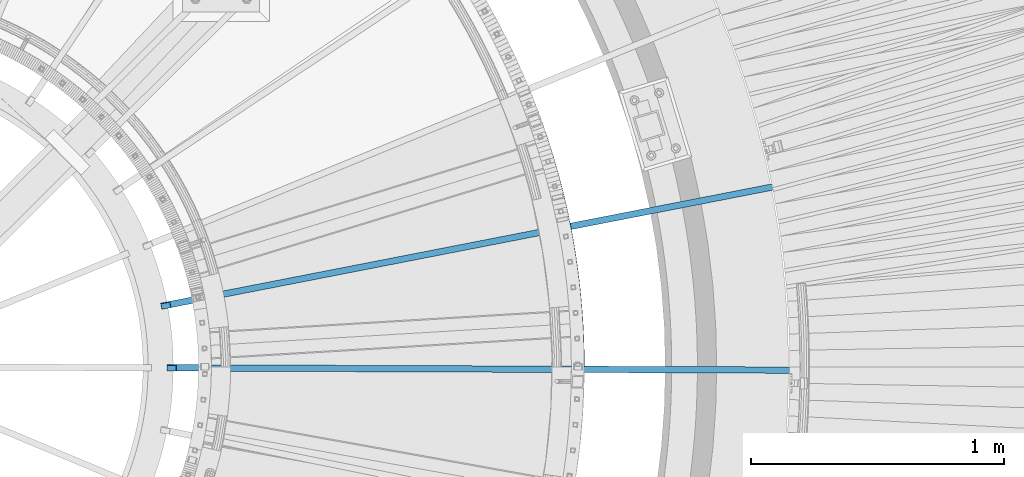
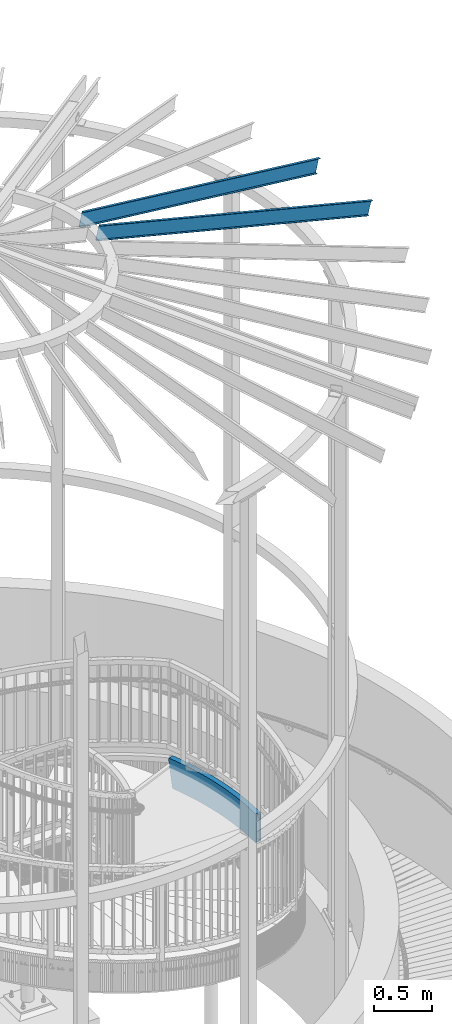
# One storey, part 364 of 975: 3 beams.
"""IFC2X3 building model written with IfcOpenShell, lengths in millimetres."""

from ifc_helpers import new_model, si_unit, frame, origin_with_axes, place, context, subcontext, project, spatial, faceted_brep, material, type_object, element, save


model = new_model("IFC2X3")

# Units and contexts
model_context = context("Model", 3, precision=1e-05, world=origin_with_axes())
body_context = subcontext(model_context, "Body", "Model", "MODEL_VIEW")
ifc_project = project(units=[si_unit("LENGTHUNIT", "METRE", prefix="MILLI"), si_unit("AREAUNIT", "SQUARE_METRE"), si_unit("VOLUMEUNIT", "CUBIC_METRE"), si_unit("MASSUNIT", "GRAM", prefix="KILO"), si_unit("TIMEUNIT", "SECOND"), si_unit("PLANEANGLEUNIT", "RADIAN"), si_unit("SOLIDANGLEUNIT", "STERADIAN"), si_unit("THERMODYNAMICTEMPERATUREUNIT", "DEGREE_CELSIUS"), si_unit("LUMINOUSINTENSITYUNIT", "LUMEN")], contexts=[model_context])

# Site, building, storey
site_placement = place(None, origin_with_axes())
site = spatial("IfcSite", under=ifc_project, at=site_placement, CompositionType="ELEMENT")
building_placement = place(site_placement, origin_with_axes())
building = spatial("IfcBuilding", under=site, at=building_placement, Name="Undefined", CompositionType="ELEMENT")
storey_placement = place(building_placement, origin_with_axes())
storey = spatial("IfcBuildingStorey", under=building, at=storey_placement, Name="Undefined", CompositionType="ELEMENT", Elevation=0.0)

# Beams
ifc_material_1 = material()
beam_type_1 = type_object("IfcBeamType", Name="HSS12X2X5/16", PredefinedType="NOTDEFINED")
beam_placement = place(storey_placement, frame((37376.4468906606, 4525.99145392499, 2031.99999923706), z_axis=(0.0, 0.0, 1.0), x_axis=(0.0625371900182985, -0.99804263429205, 0.0)))
element("IfcBeam", 1, at=beam_placement, inside=storey, type_object=beam_type_1, material=ifc_material_1, Name="STAIR", ObjectType="HSS12X2X5/16", context=body_context, shape_type="Brep", body=[
    faceted_brep([(50.4767882712349, -9.42974077601684, -152.4), (42.9468978576706, -11.9601611467078, -144.457192089878), (40.2846474015082, -4.48124712339632, -144.434568420989), (40.3111269200131, -4.47234867874795, -144.4625), (28.6915941205434, 28.4665858047883, -144.4625), (28.5707453943933, 28.4259745791787, -144.335024277875), (25.90849493823, 35.9048886024902, -144.312400608985), (33.5756496538238, 38.4814366545834, -152.4), (5.84921235797265, -16.4537418553809, 144.4625), (36.8046028404979, -5.65071642034309, 144.4625), (36.8046028404979, -5.65071642034309, -119.316739082641), (5.84921235797265, -16.4537418553809, 105.027080408093), (0.43018889700852, -18.4155836698192, 144.4625), (67.8829967902311, 4.79318074406183, -144.4625), (67.8829967902311, 4.79318074406183, 144.4625), (99.0802279445834, 14.8765495649059, 144.4625), (99.0802279445834, 14.8765495649059, -144.4625), (130.392114110062, 24.5980383004644, 144.4625), (130.392114110062, 24.5980383004644, -144.4625), (161.814457722915, 33.9563437213947, 144.4625), (161.814457722915, 33.9563437213947, -144.4625), (193.343046411844, 42.9502112854461, 144.4625), (193.343046411844, 42.9502112854461, -144.4625), (224.973653562703, 51.5784353056879, 144.4625), (224.973653562703, 51.5784353056879, -144.4625), (256.702038885101, 59.8398591120786, 144.4625), (256.702038885101, 59.8398591120786, -144.4625), (288.523948980843, 67.7333752065606, 144.4625), (288.523948980843, 67.7333752065606, -144.4625), (320.435117914123, 75.2579254115335, 144.4625), (320.435117914123, 75.2579254115335, -144.4625), (352.431267783404, 82.4125010116622, 144.4625), (352.431267783404, 82.4125010116622, -144.4625), (384.508109294894, 89.1961428891591, 144.4625), (384.508109294894, 89.1961428891591, -144.4625), (416.66134233756, 95.607941652328, 144.4625), (416.66134233756, 95.607941652328, -144.4625), (448.886656559584, 101.647037757473, 144.4625), (448.886656559584, 101.647037757473, -144.4625), (481.179731946188, 107.312621624165, 144.4625), (481.179731946188, 107.312621624165, -144.4625), (513.536239398771, 112.603933743696, 144.4625), (513.536239398771, 112.603933743696, -144.4625), (545.951841315243, 117.520264780986, 144.4625), (545.951841315243, 117.520264780986, -144.4625), (578.422192171517, 122.060955669585, 144.4625), (578.422192171517, 122.060955669585, -144.4625), (610.942939104049, 126.225397700116, 144.4625), (610.942939104049, 126.225397700116, -144.4625), (643.509722493372, 130.013032601797, 144.4625), (643.509722493372, 130.013032601797, -144.4625), (676.118176548528, 133.423352617305, 144.4625), (676.118176548528, 133.423352617305, -144.4625), (708.763929892335, 136.455900570894, 144.4625), (708.763929892335, 136.455900570894, -144.4625), (741.442606147396, 139.110269929603, 144.4625), (741.442606147396, 139.110269929603, -144.4625), (774.149824522779, 141.386104857796, 144.4625), (774.149824522779, 141.386104857796, -144.4625), (806.8812004013, 143.283100264904, 144.4625), (806.8812004013, 143.283100264904, -144.4625), (839.632345927297, 144.801001846223, 144.4625), (839.632345927297, 144.801001846223, -144.4625), (872.39887059486, 145.939606117092, 144.4625), (872.39887059486, 145.939606117092, -144.4625), (905.176381836402, 146.698760440137, 144.4625), (905.176381836402, 146.698760440137, -144.4625), (937.960485611517, 147.078363045752, 144.4625), (937.960485611517, 147.078363045752, -144.4625), (970.746786996023, 147.078363045708, 144.4625), (970.746786996023, 147.078363045708, -144.4625), (1003.53089077114, 146.698760440006, 144.4625), (1003.53089077114, 146.698760440006, -144.4625), (1036.30840201268, 145.939606116859, 144.4625), (1036.30840201268, 145.939606116859, -144.4625), (1069.07492668024, 144.801001845903, 144.4625), (1069.07492668024, 144.801001845903, -144.4625), (1101.82607220624, 143.283100264496, 144.4625), (1101.82607220624, 143.283100264496, -144.4625), (1133.45592378993, 141.449945330613, 144.4625), (1133.45592378993, 141.449945330613, -144.4625), (56.9496687240271, 37.962714391746, 144.4625), (56.9496687240271, 37.962714391746, -144.4625), (88.5316724221789, 48.1704469246324, -144.4625), (88.5316724221789, 48.1704469246324, 144.4625), (120.229745234523, 58.0118361068453, -144.4625), (120.229745234523, 58.0118361068453, 144.4625), (152.039637826455, 67.4855626356511, -144.4625), (152.039637826455, 67.4855626356511, 144.4625), (183.957085873196, 76.590356495828, -144.4625), (183.957085873196, 76.590356495828, 144.4625), (215.977810631451, 85.3249971300465, -144.4625), (215.977810631451, 85.3249971300465, 144.4625), (248.097519513003, 93.6883136024044, -144.4625), (248.097519513003, 93.6883136024044, 144.4625), (280.311906660169, 101.679184755492, -144.4625), (280.311906660169, 101.679184755492, 144.4625), (312.616653523017, 109.296539360599, -144.4625), (312.616653523017, 109.296539360599, 144.4625), (345.007429438308, 116.539356261368, -144.4625), (345.007429438308, 116.539356261368, 144.4625), (377.479892210042, 123.40666451068, -144.4625), (377.479892210042, 123.40666451068, 144.4625), (410.029688691558, 129.897543500811, -144.4625), (410.029688691558, 129.897543500811, 144.4625), (442.652455369106, 136.011123086857, -144.4625), (442.652455369106, 136.011123086857, 144.4625), (475.343818946802, 141.74658370336, -144.4625), (475.343818946802, 141.74658370336, 144.4625), (508.0993969329, 147.103156474215, -144.4625), (508.0993969329, 147.103156474215, 144.4625), (540.914798227285, 152.080123315682, -144.4625), (540.914798227285, 152.080123315682, 144.4625), (573.785623710142, 156.67681703272, -144.4625), (573.785623710142, 156.67681703272, 144.4625), (606.707466831677, 160.892621408377, -144.4625), (606.707466831677, 160.892621408377, 144.4625), (639.675914202845, 164.726971286414, -144.4625), (639.675914202845, 164.726971286414, 144.4625), (672.686546186998, 168.179352647094, -144.4625), (672.686546186998, 168.179352647094, 144.4625), (705.734937492365, 171.24930267602, -144.4625), (705.734937492365, 171.24930267602, 144.4625), (738.816657765287, 173.936409826274, -144.4625), (738.816657765287, 173.936409826274, 144.4625), (771.927272184139, 176.24031387351, -144.4625), (771.927272184139, 176.24031387351, 144.4625), (805.06234205385, 178.160705964263, -144.4625), (805.06234205385, 178.160705964263, 144.4625), (838.21742540093, 179.697328657392, -144.4625), (838.21742540093, 179.697328657392, 144.4625), (871.388077568954, 180.849975958547, -144.4625), (871.388077568954, 180.849975958547, 144.4625), (904.569851814394, 181.618493347778, -144.4625), (904.569851814394, 181.618493347778, 144.4625), (937.758299902736, 182.002777800299, -144.4625), (937.758299902736, 182.002777800299, 144.4625), (970.94897270479, 182.002777800255, -144.4625), (970.94897270479, 182.002777800255, 144.4625), (1004.13742079313, 181.618493347632, -144.4625), (1004.13742079313, 181.618493347632, 144.4625), (1037.31919503857, 180.849975958314, -144.4625), (1037.31919503857, 180.849975958314, 144.4625), (1070.4898472066, 179.697328657072, -144.4625), (1070.4898472066, 179.697328657072, 144.4625), (1103.64493055368, 178.160705963848, -144.4625), (1103.64493055368, 178.160705963848, 144.4625), (1135.64002253457, 176.306382981355, -144.4625), (1135.64002253457, 176.306382981355, 144.4625), (1136.1364086129, 184.228300629249, 144.4625), (1136.13640861289, 184.228300629249, -144.4625), (1104.05830745082, 186.087434531888, -152.4), (1104.05830745082, 186.087434531888, 152.4), (1128.21211871852, 184.687564596352, 152.4), (1128.21211916117, 184.687564570697, -152.4), (1070.8114200535, 187.628312023255, -152.4), (1070.8114200535, 187.628312023255, 152.4), (1037.54892072627, 188.784150922278, -152.4), (1037.54892072627, 188.784150922278, 152.4), (1004.2752685254, 189.554796281198, -152.4), (1004.2752685254, 189.554796281198, 152.4), (970.994924002237, 189.940144789914, -152.4), (970.994924002237, 189.940144789914, 152.4), (937.712348605286, 189.940144789965, -152.4), (937.712348605286, 189.940144789965, 152.4), (904.43200408212, 189.554796281329, -152.4), (904.43200408212, 189.554796281329, 152.4), (871.158351881248, 188.784150922511, -152.4), (871.158351881248, 188.784150922511, 152.4), (837.895852554028, 187.628312023582, -152.4), (837.895852554028, 187.628312023582, 152.4), (804.648965156702, 186.087434532303, -152.4), (804.648965156702, 186.087434532303, 152.4), (771.42214665263, 184.161725013444, -152.4), (771.42214665263, 184.161725013444, 152.4), (738.219851314807, 181.851441620973, -152.4), (738.219851314807, 181.851441620973, 152.4), (705.046530128735, 179.156894063555, -152.4), (705.046530128735, 179.156894063555, 152.4), (671.906630195741, 176.078443562947, -152.4), (671.906630195741, 176.078443562947, 152.4), (638.804594136816, 172.616502805649, -152.4), (638.804594136816, 172.616502805649, 152.4), (605.744859497046, 168.771535887528, -152.4), (605.744859497046, 168.771535887528, 152.4), (572.731858150739, 164.544058251617, -152.4), (572.731858150739, 164.544058251617, 152.4), (539.770015707295, 159.934636619022, -152.4), (539.770015707295, 159.934636619022, 152.4), (506.863750917929, 154.943888912967, -152.4), (506.863750917929, 154.943888912967, 152.4), (474.017475083306, 149.572484175907, -152.4), (474.017475083306, 149.572484175907, 152.4), (441.235591462179, 143.821142479901, -152.4), (441.235591462179, 143.821142479901, 152.4), (408.522494681103, 137.690634830011, -152.4), (408.522494681103, 137.690634830011, 152.4), (375.882570145302, 131.181783061016, -152.4), (375.882570145302, 131.181783061016, 152.4), (343.320193450787, 124.295459727211, -152.4), (343.320193450787, 124.295459727211, 152.4), (310.839729797766, 117.032587985392, -152.4), (310.839729797766, 117.032587985392, 152.4), (278.44553340547, 109.394141471159, -152.4), (278.44553340547, 109.394141471159, 152.4), (246.141946928435, 101.381144168394, -152.4), (246.141946928435, 101.381144168394, 152.4), (213.933300874347, 92.994670271939, -152.4), (213.933300874347, 92.994670271939, 152.4), (181.823913023502, 84.2358440436437, -152.4), (181.823913023502, 84.2358440436437, 152.4), (149.818087849988, 75.1058396616208, -152.4), (149.818087849988, 75.1058396616208, 152.4), (117.920115944627, 65.6058810628529, -152.4), (117.920115944627, 65.6058810628529, 152.4), (86.1342734398131, 55.7372417791048, -152.4), (86.1342734398131, 55.7372417791048, 152.4), (54.4648214362537, 45.501244766223, -152.4), (54.4648214362537, 45.501244766223, 152.4), (22.9160054317458, 34.8992622267615, -122.713585018293), (22.9160054317458, 34.8992622267615, 152.4), (-8.50794524795992, 23.93271542601, 105.026043171934), (-8.50794524795992, 23.93271542601, 150.251089587742), (-6.47902665908623, 24.6407814132108, 152.4), (-13.930158757054, 21.9697187227212, 144.484677442171), (8.50794524795947, -23.9327154259954, 105.027272488863), (39.3765653235992, -13.1599717253703, -118.687693539002), (39.3765653235992, -13.1599717253703, 152.4), (10.4203217331333, -23.2653211050638, 152.4), (8.50794524795947, -23.9327154259954, 150.374524082099), (3.07108006647468, -25.9010164546562, 144.592530185369), (70.3678440780036, -2.74534963041515, 152.4), (101.477626926949, 7.30975471043348, 152.4), (132.701743399958, 17.0039933444714, 152.4), (164.036007699384, 26.336066695425, 152.4), (195.476219261537, 35.3047237376304, 152.4), (227.018163319806, 43.9087621637882, 152.4), (258.65761146967, 52.1470285460964, 152.4), (290.390322235542, 60.0184184909012, 152.4), (322.212041639375, 67.5218767867409, 152.4), (354.118503770926, 74.6563975458121, 152.4), (386.105431359633, 81.4210243388079, 152.4), (418.168536348015, 87.8148503231132, 152.4), (450.303520466511, 93.8370183644365, 152.4), (482.506075809685, 99.4867211516103, 152.4), (514.771885413742, 104.763201304937, 152.4), (547.096623835234, 109.665751477638, 152.4), (579.47595773092, 114.193714450696, 152.4), (611.905546438679, 118.346483220965, 152.4), (644.381042559401, 122.123501082555, 152.4), (676.898092539784, 125.524261701445, 152.4), (709.452337255965, 128.548309183367, 152.4), (742.039412597875, 131.195238134904, 152.4), (774.654950054289, 133.464693717877, 152.4), (807.294577298449, 135.356371696871, 152.4), (839.953918774198, 136.870018480047, 152.4), (872.628596282565, 138.005431153128, 152.4), (905.314229568676, 138.762457506586, 152.4), (938.006436908966, 139.140996056085, 152.4), (970.700835698576, 139.140996056034, 152.4), (1003.39304303887, 138.762457506447, 152.4), (1036.07867632498, 138.005431152895, 152.4), (1068.75335383335, 136.870018479727, 152.4), (1101.4126953091, 135.356371696456, 152.4), (1125.03524781722, 133.987291649828, 152.4), (1132.9595377116, 133.528027682718, 144.4625), (1101.4126953091, 135.356371696456, -152.4), (1125.03524825988, 133.987291624166, -152.4), (1132.9595377116, 133.528027682718, -144.4625), (1068.75335383335, 136.870018479727, -152.4), (1036.07867632498, 138.005431152895, -152.4), (1003.39304303887, 138.762457506447, -152.4), (970.700835698576, 139.140996056034, -152.4), (938.006436908966, 139.140996056085, -152.4), (905.314229568676, 138.762457506586, -152.4), (872.628596282565, 138.005431153128, -152.4), (839.953918774198, 136.870018480047, -152.4), (807.294577298449, 135.356371696871, -152.4), (774.654950054289, 133.464693717877, -152.4), (742.039412597875, 131.195238134904, -152.4), (709.452337255965, 128.548309183367, -152.4), (676.898092539784, 125.524261701445, -152.4), (644.381042559401, 122.123501082555, -152.4), (611.905546438679, 118.346483220965, -152.4), (579.47595773092, 114.193714450696, -152.4), (547.096623835234, 109.665751477638, -152.4), (514.771885413742, 104.763201304937, -152.4), (482.506075809685, 99.4867211516103, -152.4), (450.303520466511, 93.8370183644365, -152.4), (418.168536348015, 87.8148503231132, -152.4), (386.105431359633, 81.4210243388079, -152.4), (354.118503770926, 74.6563975458121, -152.4), (322.212041639375, 67.5218767867409, -152.4), (290.390322235542, 60.0184184909012, -152.4), (258.65761146967, 52.1470285460964, -152.4), (227.018163319806, 43.9087621637882, -152.4), (195.476219261537, 35.3047237376304, -152.4), (164.036007699384, 26.336066695425, -152.4), (132.701743399958, 17.0039933444714, -152.4), (101.477626926949, 7.30975471043348, -152.4), (70.3678440780036, -2.74534963041515, -152.4), (-11.2683519560769, 14.4918579959703, 144.4625), (-5.84921235797174, 16.4537418553809, 144.4625), (25.4879679148476, 27.3900069217416, 144.4625), (-5.84921235797174, 16.4537418553809, 105.026235252704), (25.4879679148476, 27.3900069217416, -122.084539474654)], [[[0, 1, 2, 3, 4, 5, 6, 7]], [[8, 9, 10, 11]], [[8, 11, 12]], [[13, 14, 15, 16]], [[16, 15, 17, 18]], [[18, 17, 19, 20]], [[20, 19, 21, 22]], [[22, 21, 23, 24]], [[24, 23, 25, 26]], [[26, 25, 27, 28]], [[28, 27, 29, 30]], [[30, 29, 31, 32]], [[32, 31, 33, 34]], [[34, 33, 35, 36]], [[36, 35, 37, 38]], [[38, 37, 39, 40]], [[40, 39, 41, 42]], [[42, 41, 43, 44]], [[44, 43, 45, 46]], [[46, 45, 47, 48]], [[48, 47, 49, 50]], [[50, 49, 51, 52]], [[52, 51, 53, 54]], [[54, 53, 55, 56]], [[56, 55, 57, 58]], [[58, 57, 59, 60]], [[60, 59, 61, 62]], [[62, 61, 63, 64]], [[64, 63, 65, 66]], [[66, 65, 67, 68]], [[68, 67, 69, 70]], [[70, 69, 71, 72]], [[72, 71, 73, 74]], [[74, 73, 75, 76]], [[76, 75, 77, 78]], [[78, 77, 79, 80]], [[81, 82, 83, 84]], [[84, 83, 85, 86]], [[86, 85, 87, 88]], [[88, 87, 89, 90]], [[90, 89, 91, 92]], [[92, 91, 93, 94]], [[94, 93, 95, 96]], [[96, 95, 97, 98]], [[98, 97, 99, 100]], [[100, 99, 101, 102]], [[102, 101, 103, 104]], [[104, 103, 105, 106]], [[106, 105, 107, 108]], [[108, 107, 109, 110]], [[110, 109, 111, 112]], [[112, 111, 113, 114]], [[114, 113, 115, 116]], [[116, 115, 117, 118]], [[118, 117, 119, 120]], [[120, 119, 121, 122]], [[122, 121, 123, 124]], [[124, 123, 125, 126]], [[126, 125, 127, 128]], [[128, 127, 129, 130]], [[130, 129, 131, 132]], [[132, 131, 133, 134]], [[134, 133, 135, 136]], [[136, 135, 137, 138]], [[138, 137, 139, 140]], [[140, 139, 141, 142]], [[142, 141, 143, 144]], [[144, 143, 145, 146]], [[146, 145, 147, 148]], [[149, 148, 147, 150]], [[151, 152, 153, 149, 150, 154]], [[155, 156, 152, 151]], [[157, 158, 156, 155]], [[159, 160, 158, 157]], [[161, 162, 160, 159]], [[163, 164, 162, 161]], [[165, 166, 164, 163]], [[167, 168, 166, 165]], [[169, 170, 168, 167]], [[171, 172, 170, 169]], [[173, 174, 172, 171]], [[175, 176, 174, 173]], [[177, 178, 176, 175]], [[179, 180, 178, 177]], [[181, 182, 180, 179]], [[183, 184, 182, 181]], [[185, 186, 184, 183]], [[187, 188, 186, 185]], [[189, 190, 188, 187]], [[191, 192, 190, 189]], [[193, 194, 192, 191]], [[195, 196, 194, 193]], [[197, 198, 196, 195]], [[199, 200, 198, 197]], [[201, 202, 200, 199]], [[203, 204, 202, 201]], [[205, 206, 204, 203]], [[207, 208, 206, 205]], [[209, 210, 208, 207]], [[211, 212, 210, 209]], [[213, 214, 212, 211]], [[215, 216, 214, 213]], [[217, 218, 216, 215]], [[219, 220, 218, 217, 7, 6]], [[220, 219, 221, 222, 223]], [[221, 224, 222]], [[225, 226, 227, 228, 229]], [[225, 229, 230]], [[228, 223, 222, 224, 230, 229]], [[227, 231, 232, 233, 234, 235, 236, 237, 238, 239, 240, 241, 242, 243, 244, 245, 246, 247, 248, 249, 250, 251, 252, 253, 254, 255, 256, 257, 258, 259, 260, 261, 262, 263, 264, 153, 152, 156, 158, 160, 162, 164, 166, 168, 170, 172, 174, 176, 178, 180, 182, 184, 186, 188, 190, 192, 194, 196, 198, 200, 202, 204, 206, 208, 210, 212, 214, 216, 218, 220, 223, 228]], [[265, 264, 263, 266, 267, 268]], [[262, 269, 266, 263]], [[261, 270, 269, 262]], [[260, 271, 270, 261]], [[259, 272, 271, 260]], [[258, 273, 272, 259]], [[257, 274, 273, 258]], [[256, 275, 274, 257]], [[255, 276, 275, 256]], [[254, 277, 276, 255]], [[253, 278, 277, 254]], [[252, 279, 278, 253]], [[251, 280, 279, 252]], [[250, 281, 280, 251]], [[249, 282, 281, 250]], [[248, 283, 282, 249]], [[247, 284, 283, 248]], [[246, 285, 284, 247]], [[245, 286, 285, 246]], [[244, 287, 286, 245]], [[243, 288, 287, 244]], [[242, 289, 288, 243]], [[241, 290, 289, 242]], [[240, 291, 290, 241]], [[239, 292, 291, 240]], [[238, 293, 292, 239]], [[237, 294, 293, 238]], [[236, 295, 294, 237]], [[235, 296, 295, 236]], [[234, 297, 296, 235]], [[233, 298, 297, 234]], [[232, 299, 298, 233]], [[231, 300, 299, 232]], [[217, 215, 213, 211, 209, 207, 205, 203, 201, 199, 197, 195, 193, 191, 189, 187, 185, 183, 181, 179, 177, 175, 173, 171, 169, 167, 165, 163, 161, 159, 157, 155, 151, 154, 267, 266, 269, 270, 271, 272, 273, 274, 275, 276, 277, 278, 279, 280, 281, 282, 283, 284, 285, 286, 287, 288, 289, 290, 291, 292, 293, 294, 295, 296, 297, 298, 299, 300, 0, 7]], [[150, 147, 80, 268, 267, 154]], [[79, 265, 268, 80]], [[149, 153, 264, 265, 79, 148]], [[77, 75, 73, 71, 69, 67, 65, 63, 61, 59, 57, 55, 53, 51, 49, 47, 45, 43, 41, 39, 37, 35, 33, 31, 29, 27, 25, 23, 21, 19, 17, 15, 14, 9, 8, 12, 301, 302, 303, 81, 84, 86, 88, 90, 92, 94, 96, 98, 100, 102, 104, 106, 108, 110, 112, 114, 116, 118, 120, 122, 124, 126, 128, 130, 132, 134, 136, 138, 140, 142, 144, 146, 148, 79]], [[302, 301, 304]], [[303, 302, 304, 305]], [[82, 81, 303, 305, 5, 4]], [[13, 16, 18, 20, 22, 24, 26, 28, 30, 32, 34, 36, 38, 40, 42, 44, 46, 48, 50, 52, 54, 56, 58, 60, 62, 64, 66, 68, 70, 72, 74, 76, 78, 80, 147, 145, 143, 141, 139, 137, 135, 133, 131, 129, 127, 125, 123, 121, 119, 117, 115, 113, 111, 109, 107, 105, 103, 101, 99, 97, 95, 93, 91, 89, 87, 85, 83, 82, 4, 3]], [[10, 9, 14, 13, 3, 2]], [[226, 225, 230, 224, 221, 219, 6, 5, 305, 304, 301, 12, 11, 10, 2, 1]], [[300, 231, 227, 226, 1, 0]]]),
])
ifc_material_2 = material(Name="STEEL/Zero_Density")
beam_type_2 = type_object("IfcBeamType", PredefinedType="NOTDEFINED")
for number, where, z_axis, x_axis, name in (
    (2, (35976.6284790081, 3646.30018988136, 8885.0313138005), (0.238053331947034, 0.0464456919896647, 0.970140922157455), (0.952186998609667, 0.185777631923843, -0.242541936900574), "STUD"),
    (3, (36000.1097867782, 3399.3095288316, 8885.0313138005), (0.242540308898344, -0.000888649999627433, 0.970140922165782), (0.970134410469096, -0.00355450199805463, -0.242541936867269), "STUD"),
):
    element("IfcBeam", number, at=place(storey_placement, frame(where, z_axis=z_axis, x_axis=x_axis)), inside=storey, type_object=beam_type_2, material=ifc_material_2, Name=name, context=body_context, shape_type="Brep", body=[
        faceted_brep([(-1.67347025126219e-10, 12.6999999998588, -76.2000000000985), (1.96450855582952e-10, 12.7000000001644, 76.2000000001021), (2798.98467503002, 12.7000000041553, 76.2000000028588), (2798.98467502966, 12.7000000038533, -76.1999999973427), (1.74622982740402e-10, -12.6999999998661, 76.2000000000985), (2798.98467503, -12.6999999958753, 76.2000000028534), (1.67347025126219e-10, -12.6999999998698, 73.0250000000947), (2798.98467502999, -12.6999999958789, 73.0250000028504), (1.89174897968769e-10, 9.52500000015425, 73.0250000000974), (2798.98467503001, 9.52500000414511, 73.0250000028532), (-1.60071067512035e-10, 9.52499999986321, -73.0250000000938), (2798.98467502966, 9.52500000385407, -73.0249999973398), (-1.81898940354586e-10, -12.7000000001608, -73.0250000000965), (2798.98467502964, -12.6999999961699, -73.0249999973416), (-1.92812876775861e-10, -12.7000000001717, -76.2000000001003), (2798.98467502963, -12.6999999961772, -76.1999999973455)], [[[0, 1, 2, 3]], [[1, 4, 5, 2]], [[4, 6, 7, 5]], [[6, 8, 9, 7]], [[8, 10, 11, 9]], [[10, 12, 13, 11]], [[12, 14, 15, 13]], [[14, 0, 3, 15]], [[5, 7, 9, 11, 13, 15, 3, 2]], [[14, 12, 10, 8, 6, 4, 1, 0]]]),
    ])

save(model, "model.ifc")
